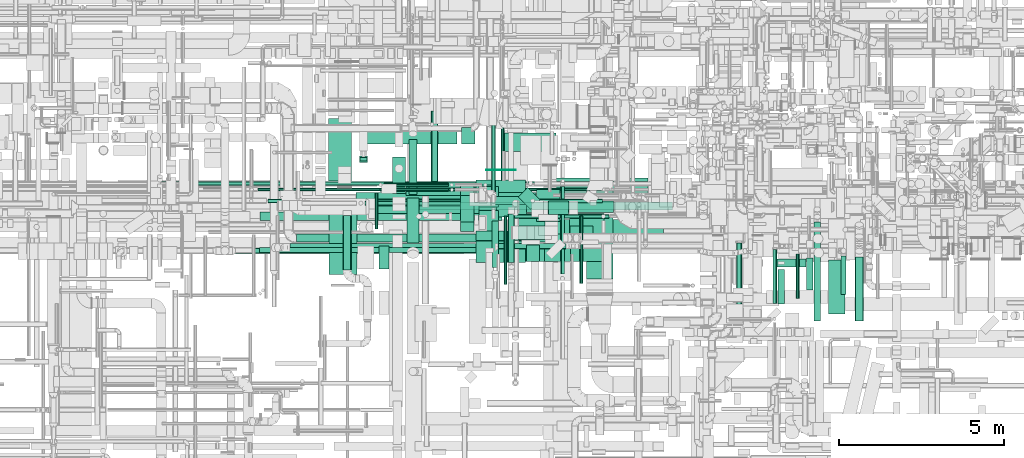
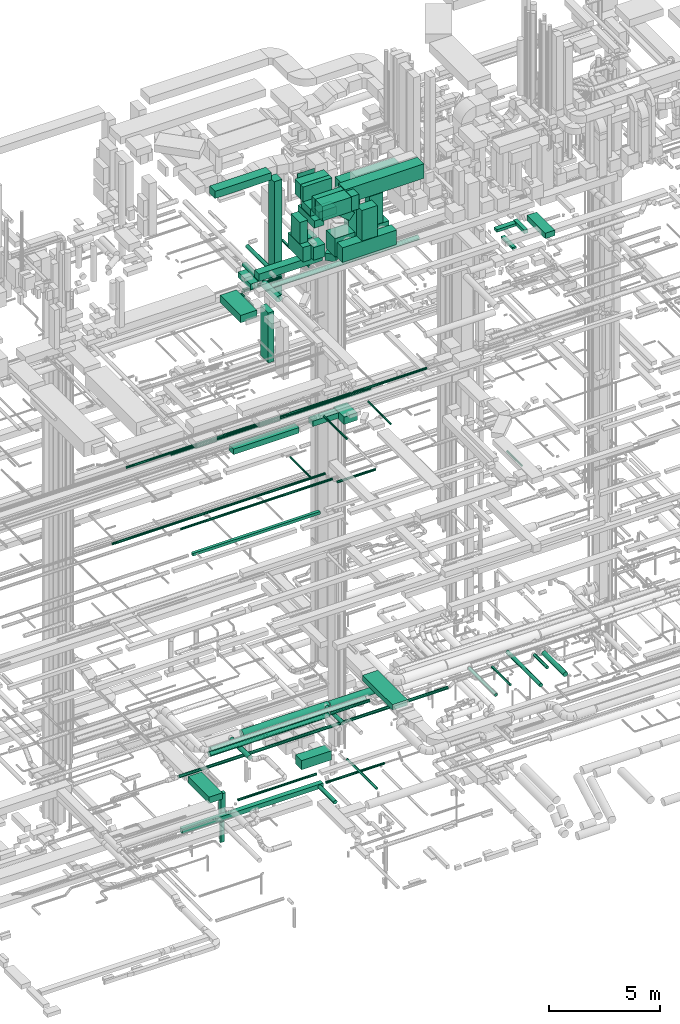
# One storey, part 40 of 337: 77 flow segments.
"""IFC2X3 building model written with IfcOpenShell, lengths in millimetres."""

from ifc_helpers import new_model, entity, si_unit, converted_unit, derived_unit, direction, frame, origin, origin_2d_with_axis, place, context, subcontext, project, spatial, rectangle, circle, extrude, type_object, element, save


model = new_model("IFC2X3")

# Units and contexts
model_context = context("Model", 3, precision=0.01, world=origin(), true_north=direction((6.12303176911189e-17, 1.0)))
body_context = subcontext(model_context, "Body", "Model", "MODEL_VIEW")
ifc_project = project(units=[si_unit("LENGTHUNIT", "METRE", prefix="MILLI"), si_unit("AREAUNIT", "SQUARE_METRE"), si_unit("VOLUMEUNIT", "CUBIC_METRE"), converted_unit("PLANEANGLEUNIT", "DEGREE", entity("IfcRatioMeasure", 0.0174532925199433), si_unit("PLANEANGLEUNIT", "RADIAN"), dimensions=[0, 0, 0, 0, 0, 0, 0]), si_unit("MASSUNIT", "GRAM", prefix="KILO"), derived_unit("MASSDENSITYUNIT", [(si_unit("MASSUNIT", "GRAM", prefix="KILO"), 1), (si_unit("LENGTHUNIT", "METRE"), -3)]), derived_unit("MOMENTOFINERTIAUNIT", [(si_unit("LENGTHUNIT", "METRE"), 4)]), si_unit("TIMEUNIT", "SECOND"), si_unit("FREQUENCYUNIT", "HERTZ"), si_unit("THERMODYNAMICTEMPERATUREUNIT", "DEGREE_CELSIUS"), derived_unit("THERMALTRANSMITTANCEUNIT", [(si_unit("MASSUNIT", "GRAM", prefix="KILO"), 1), (si_unit("THERMODYNAMICTEMPERATUREUNIT", "KELVIN"), -1), (si_unit("TIMEUNIT", "SECOND"), -3)]), derived_unit("VOLUMETRICFLOWRATEUNIT", [(si_unit("LENGTHUNIT", "METRE"), 3), (si_unit("TIMEUNIT", "SECOND"), -1)]), derived_unit("MASSFLOWRATEUNIT", [(si_unit("MASSUNIT", "GRAM", prefix="KILO"), 1), (si_unit("TIMEUNIT", "SECOND"), -1)]), derived_unit("ROTATIONALFREQUENCYUNIT", [(si_unit("TIMEUNIT", "SECOND"), -1)]), si_unit("ELECTRICCURRENTUNIT", "AMPERE"), si_unit("ELECTRICVOLTAGEUNIT", "VOLT"), si_unit("POWERUNIT", "WATT"), si_unit("FORCEUNIT", "NEWTON", prefix="KILO"), si_unit("ILLUMINANCEUNIT", "LUX"), si_unit("LUMINOUSFLUXUNIT", "LUMEN"), si_unit("LUMINOUSINTENSITYUNIT", "CANDELA"), derived_unit("USERDEFINED", [(si_unit("MASSUNIT", "GRAM", prefix="KILO"), -1), (si_unit("LENGTHUNIT", "METRE"), -2), (si_unit("TIMEUNIT", "SECOND"), 3), (si_unit("LUMINOUSFLUXUNIT", "LUMEN"), 1)]), derived_unit("LINEARVELOCITYUNIT", [(si_unit("LENGTHUNIT", "METRE"), 1), (si_unit("TIMEUNIT", "SECOND"), -1)]), si_unit("PRESSUREUNIT", "PASCAL"), derived_unit("USERDEFINED", [(si_unit("LENGTHUNIT", "METRE"), -2), (si_unit("MASSUNIT", "GRAM", prefix="KILO"), 1), (si_unit("TIMEUNIT", "SECOND"), -2)]), derived_unit("LINEARFORCEUNIT", [(si_unit("MASSUNIT", "GRAM", prefix="KILO"), 1), (si_unit("LENGTHUNIT", "METRE"), 1), (si_unit("TIMEUNIT", "SECOND"), -2), (si_unit("LENGTHUNIT", "METRE"), -1)]), derived_unit("PLANARFORCEUNIT", [(si_unit("MASSUNIT", "GRAM", prefix="KILO"), 1), (si_unit("LENGTHUNIT", "METRE"), 1), (si_unit("TIMEUNIT", "SECOND"), -2), (si_unit("LENGTHUNIT", "METRE"), -2)])], contexts=[model_context])

# Site, building, storey
site_placement = place(None, origin())
site = spatial("IfcSite", under=ifc_project, at=site_placement, CompositionType="ELEMENT")
building_placement = place(site_placement, origin())
building = spatial("IfcBuilding", under=site, at=building_placement, CompositionType="ELEMENT")
storey_placement = place(building_placement, origin())
storey = spatial("IfcBuildingStorey", under=building, at=storey_placement, CompositionType="ELEMENT", Elevation=0.0)

# Flow segments
duct_segment_type_1 = type_object("IfcDuctSegmentType", PredefinedType="NOTDEFINED")
flow_segment_1_placement = place(storey_placement, frame((37959.51, 10320.01, -800.0)))
element("IfcFlowSegment", 1, at=flow_segment_1_placement, inside=storey, type_object=duct_segment_type_1, context=body_context, shape_type="SweptSolid", body=[
    extrude(rectangle(XDim=1895.67384788931, YDim=700.000000000001, at=origin_2d_with_axis()), frame((350.0, 947.84, 0.0), z_axis=(0.0, 0.0, 1.0), x_axis=(0.0, 1.0, 0.0)), (0.0, 0.0, 1.0), 350.0),
])
flow_segment_2_placement = place(storey_placement, frame((43284.29, 11214.6, -1350.0)))
element("IfcFlowSegment", 2, at=flow_segment_2_placement, inside=storey, type_object=duct_segment_type_1, context=body_context, shape_type="SweptSolid", body=[
    extrude(rectangle(XDim=1570.65169441701, YDim=550.000000000001, at=origin_2d_with_axis()), frame((785.33, 275.0, 0.0), z_axis=(0.0, 0.0, 1.0), x_axis=(-1.0, 0.0, 0.0)), (0.0, 0.0, 1.0), 500.0),
])
flow_segment_3_placement = place(storey_placement, frame((38896.44, 10873.03, -2250.0)))
element("IfcFlowSegment", 3, at=flow_segment_3_placement, inside=storey, type_object=duct_segment_type_1, context=body_context, shape_type="SweptSolid", body=[
    extrude(rectangle(XDim=249.999999999999, YDim=200.0, at=origin_2d_with_axis()), frame((125.0, 100.0, 0.0)), (0.0, 0.0, 1.0), 1300.00004199995),
])
flow_segment_4_placement = place(storey_placement, frame((38921.44, 10923.03, -3660.0)))
element("IfcFlowSegment", 4, at=flow_segment_4_placement, inside=storey, type_object=duct_segment_type_1, context=body_context, shape_type="SweptSolid", body=[
    extrude(rectangle(XDim=99.9999999999989, YDim=199.999999999998, at=origin_2d_with_axis()), frame((100.0, 50.0, 0.0), z_axis=(0.0, 0.0, 1.0), x_axis=(0.0, -1.0, 0.0)), (0.0, 0.0, 1.0), 1109.99995800006),
])
flow_segment_5_placement = place(storey_placement, frame((35887.72, 9120.01, -1025.0)))
element("IfcFlowSegment", 5, at=flow_segment_5_placement, inside=storey, type_object=duct_segment_type_1, context=body_context, shape_type="SweptSolid", body=[
    extrude(rectangle(XDim=7324.49625800008, YDim=250.000000000001, at=origin_2d_with_axis()), frame((3662.25, 125.0, 0.0)), (0.0, 0.0, 1.0), 250.0),
])
flow_segment_6_placement = place(storey_placement, frame((42932.11, 9560.56, 18650.0)))
element("IfcFlowSegment", 6, at=flow_segment_6_placement, inside=storey, type_object=duct_segment_type_1, context=body_context, shape_type="SweptSolid", body=[
    extrude(rectangle(XDim=1318.1063930437, YDim=400.0, at=origin_2d_with_axis()), frame((659.05, 200.0, 0.0), z_axis=(0.0, 0.0, 1.0), x_axis=(-1.0, 0.0, 0.0)), (0.0, 0.0, 1.0), 300.000000000001),
])
flow_segment_7_placement = place(storey_placement, frame((44270.22, 9096.34, 18575.0)))
element("IfcFlowSegment", 7, at=flow_segment_7_placement, inside=storey, type_object=duct_segment_type_1, context=body_context, shape_type="SweptSolid", body=[
    extrude(rectangle(XDim=960.0, YDim=699.999999999997, at=origin_2d_with_axis()), frame((350.0, 480.0, 0.0), z_axis=(0.0, 0.0, 1.0), x_axis=(0.0, -1.0, 0.0)), (0.0, 0.0, 1.0), 400.0),
])
flow_segment_8_placement = place(storey_placement, frame((35870.56, 8144.63, 14850.0)))
element("IfcFlowSegment", 8, at=flow_segment_8_placement, inside=storey, type_object=duct_segment_type_1, context=body_context, shape_type="SweptSolid", body=[
    extrude(rectangle(XDim=6620.00000000006, YDim=150.000000000001, at=origin_2d_with_axis()), frame((3310.0, 75.0, 0.0), z_axis=(0.0, 0.0, 1.0), x_axis=(-1.0, 0.0, 0.0)), (0.0, 0.0, 1.0), 150.000000000001),
])
flow_segment_9_placement = place(storey_placement, frame((53115.82, 6282.55, 27400.0)))
element("IfcFlowSegment", 9, at=flow_segment_9_placement, inside=storey, type_object=duct_segment_type_1, context=body_context, shape_type="SweptSolid", body=[
    extrude(rectangle(XDim=1643.01593128804, YDim=499.999999999999, at=origin_2d_with_axis()), frame((250.0, 821.51, 0.0), z_axis=(0.0, 0.0, 1.0), x_axis=(0.0, -1.0, 0.0)), (0.0, 0.0, 1.0), 300.000000000001),
])
flow_segment_10_placement = place(storey_placement, frame((52445.02, 7019.99, 27450.0)))
element("IfcFlowSegment", 10, at=flow_segment_10_placement, inside=storey, type_object=duct_segment_type_1, context=body_context, shape_type="SweptSolid", body=[
    extrude(rectangle(XDim=960.80000000287, YDim=199.999999999998, at=origin_2d_with_axis()), frame((100.0, 480.4, 0.0), z_axis=(0.0, 0.0, 1.0), x_axis=(0.0, -1.0, 0.0)), (0.0, 0.0, 1.0), 199.999999999998),
])
flow_segment_11_placement = place(storey_placement, frame((51425.02, 7708.07, 27475.0)))
element("IfcFlowSegment", 11, at=flow_segment_11_placement, inside=storey, type_object=duct_segment_type_1, context=body_context, shape_type="SweptSolid", body=[
    extrude(rectangle(XDim=1000.00000000006, YDim=249.999999999999, at=origin_2d_with_axis()), frame((500.0, 125.0, 0.0)), (0.0, 0.0, 1.0), 150.000000000001),
])
flow_segment_12_placement = place(storey_placement, frame((51586.05, 6591.62, 27150.0)))
element("IfcFlowSegment", 12, at=flow_segment_12_placement, inside=storey, type_object=duct_segment_type_1, context=body_context, shape_type="SweptSolid", body=[
    extrude(rectangle(XDim=1041.44660940674, YDim=199.999999999998, at=origin_2d_with_axis()), frame((100.0, 520.72, 0.0), z_axis=(0.0, 0.0, 1.0), x_axis=(0.0, 1.0, 0.0)), (0.0, 0.0, 1.0), 100.000000000003),
])
flow_segment_13_placement = place(storey_placement, frame((44626.69, 9306.67, 27350.0)))
element("IfcFlowSegment", 13, at=flow_segment_13_placement, inside=storey, type_object=duct_segment_type_1, context=body_context, shape_type="SweptSolid", body=[
    extrude(rectangle(XDim=400.000000000001, YDim=600.000000000002, at=origin_2d_with_axis()), frame((300.0, 200.0, 0.0), z_axis=(0.0, 0.0, 1.0), x_axis=(0.0, -1.0, 0.0)), (0.0, 0.0, 1.0), 3330.0),
])
flow_segment_14_placement = place(storey_placement, frame((40313.85, 9882.41, 27350.0)))
element("IfcFlowSegment", 14, at=flow_segment_14_placement, inside=storey, type_object=duct_segment_type_1, context=body_context, shape_type="SweptSolid", body=[
    extrude(rectangle(XDim=3290.02525316941, YDim=400.0, at=origin_2d_with_axis()), frame((1645.01, 200.0, 0.0)), (0.0, 0.0, 1.0), 399.999999999996),
])
flow_segment_15_placement = place(storey_placement, frame((38798.74, 9560.56, 18550.0)))
element("IfcFlowSegment", 15, at=flow_segment_15_placement, inside=storey, type_object=duct_segment_type_1, context=body_context, shape_type="SweptSolid", body=[
    extrude(rectangle(XDim=3408.10639304378, YDim=400.0, at=origin_2d_with_axis()), frame((1704.05, 200.0, 0.0)), (0.0, 0.0, 1.0), 300.000000000001),
])
flow_segment_16_placement = place(storey_placement, frame((38920.03, 11440.3, 31450.0)))
element("IfcFlowSegment", 16, at=flow_segment_16_placement, inside=storey, type_object=duct_segment_type_1, context=body_context, shape_type="SweptSolid", body=[
    extrude(rectangle(XDim=2927.60197550554, YDim=500.000000000001, at=origin_2d_with_axis()), frame((1463.8, 250.0, 0.0)), (0.0, 0.0, 1.0), 399.999999999996),
])
flow_segment_17_placement = place(storey_placement, frame((42435.45, 7846.66, 31160.0)))
element("IfcFlowSegment", 17, at=flow_segment_17_placement, inside=storey, type_object=duct_segment_type_1, context=body_context, shape_type="SweptSolid", body=[
    extrude(rectangle(XDim=657.000000000002, YDim=1500.0, at=origin_2d_with_axis()), frame((750.0, 328.5, 0.0), z_axis=(0.0, 0.0, 1.0), x_axis=(0.0, -1.0, 0.0)), (0.0, 0.0, 1.0), 800.0),
])
flow_segment_18_placement = place(storey_placement, frame((37970.62, 7487.81, 27350.0)))
element("IfcFlowSegment", 18, at=flow_segment_18_placement, inside=storey, type_object=duct_segment_type_1, context=body_context, shape_type="SweptSolid", body=[
    extrude(rectangle(XDim=1852.15580735637, YDim=850.000000000002, at=origin_2d_with_axis()), frame((425.0, 926.08, 0.0), z_axis=(0.0, 0.0, 1.0), x_axis=(0.0, 1.0, 0.0)), (0.0, 0.0, 1.0), 399.999999999996),
])
flow_segment_19_placement = place(storey_placement, frame((39495.62, 7650.31, 24500.0)))
element("IfcFlowSegment", 19, at=flow_segment_19_placement, inside=storey, type_object=duct_segment_type_1, context=body_context, shape_type="SweptSolid", body=[
    extrude(rectangle(XDim=700.000000000001, YDim=300.000000000001, at=origin_2d_with_axis()), frame((150.0, 350.0, 0.0), z_axis=(0.0, 0.0, 1.0), x_axis=(0.0, 1.0, 0.0)), (0.0, 0.0, 1.0), 2750.0),
])
flow_segment_20_placement = place(storey_placement, frame((42735.45, 10646.66, 31460.0)))
element("IfcFlowSegment", 20, at=flow_segment_20_placement, inside=storey, type_object=duct_segment_type_1, context=body_context, shape_type="SweptSolid", body=[
    extrude(rectangle(XDim=5.17184841368411, YDim=900.000000000003, at=origin_2d_with_axis()), frame((450.0, 2.59, 0.0), z_axis=(0.0, 0.0, 1.0), x_axis=(0.0, 1.0, 0.0)), (0.0, 0.0, 1.0), 499.999999999999),
])
flow_segment_21_placement = place(storey_placement, frame((43955.45, 7874.6, 31151.2)))
element("IfcFlowSegment", 21, at=flow_segment_21_placement, inside=storey, type_object=duct_segment_type_1, context=body_context, shape_type="SweptSolid", body=[
    extrude(rectangle(XDim=393.267745000608, YDim=500.0, at=origin_2d_with_axis()), frame((196.63, 250.0, 0.0)), (0.0, 0.0, 1.0), 800.0),
])
flow_segment_22_placement = place(storey_placement, frame((42435.45, 9849.66, 31160.0)))
element("IfcFlowSegment", 22, at=flow_segment_22_placement, inside=storey, type_object=duct_segment_type_1, context=body_context, shape_type="SweptSolid", body=[
    extrude(rectangle(XDim=496.999999999887, YDim=1500.0, at=origin_2d_with_axis()), frame((750.0, 248.5, 0.0), z_axis=(0.0, 0.0, 1.0), x_axis=(0.0, -1.0, 0.0)), (0.0, 0.0, 1.0), 800.0),
])
flow_segment_23_placement = place(storey_placement, frame((42435.45, 9601.2, 31160.0)))
element("IfcFlowSegment", 23, at=flow_segment_23_placement, inside=storey, type_object=duct_segment_type_1, context=body_context, shape_type="SweptSolid", body=[
    extrude(rectangle(XDim=242.458659614557, YDim=1500.0, at=origin_2d_with_axis()), frame((750.0, 121.23, 0.0), z_axis=(0.0, 0.0, 1.0), x_axis=(0.0, -1.0, 0.0)), (0.0, 0.0, 1.0), 800.0),
])
flow_segment_24_placement = place(storey_placement, frame((42435.45, 8509.66, 31160.0)))
element("IfcFlowSegment", 24, at=flow_segment_24_placement, inside=storey, type_object=duct_segment_type_1, context=body_context, shape_type="SweptSolid", body=[
    extrude(rectangle(XDim=291.541340385442, YDim=1500.0, at=origin_2d_with_axis()), frame((750.0, 145.77, 0.0), z_axis=(0.0, 0.0, 1.0), x_axis=(0.0, 1.0, 0.0)), (0.0, 0.0, 1.0), 800.0),
])
flow_segment_25_placement = place(storey_placement, frame((44498.71, 7874.6, 29320.0)))
element("IfcFlowSegment", 25, at=flow_segment_25_placement, inside=storey, type_object=duct_segment_type_1, context=body_context, shape_type="SweptSolid", body=[
    extrude(rectangle(XDim=800.000000000009, YDim=500.0, at=origin_2d_with_axis()), frame((400.0, 250.0, 0.0)), (0.0, 0.0, 1.0), 1681.19764904033),
])
flow_segment_26_placement = place(storey_placement, frame((43488.79, 7874.6, 28500.0)))
element("IfcFlowSegment", 26, at=flow_segment_26_placement, inside=storey, type_object=duct_segment_type_1, context=body_context, shape_type="SweptSolid", body=[
    extrude(rectangle(XDim=2820.0, YDim=500.0, at=origin_2d_with_axis()), frame((1410.0, 250.0, 0.0)), (0.0, 0.0, 1.0), 800.0),
])
for number, where in (
    (27, (45268.79, 8549.6, 28400.0)),
    (28, (43482.17, 8549.6, 28400.0)),
):
    element("IfcFlowSegment", number, at=place(storey_placement, frame(where)), inside=storey, type_object=duct_segment_type_1, context=body_context, shape_type="SweptSolid", body=[
        extrude(rectangle(XDim=1040.0, YDim=780.0, at=origin_2d_with_axis()), frame((520.0, 390.0, 0.0), z_axis=(0.0, 0.0, 1.0), x_axis=(-1.0, 0.0, 0.0)), (0.0, 0.0, 1.0), 1000.0),
    ])
flow_segment_27_placement = place(storey_placement, frame((43697.38, 8549.6, 30135.0)))
element("IfcFlowSegment", 29, at=flow_segment_27_placement, inside=storey, type_object=duct_segment_type_1, context=body_context, shape_type="SweptSolid", body=[
    extrude(rectangle(XDim=442.273616793504, YDim=400.0, at=origin_2d_with_axis()), frame((139.96, 200.0, 614.25), z_axis=(0.774227896782653, 0.0, -0.632906915623071), x_axis=(0.632906915623071, 0.0, 0.774227896782653)), (0.0, 0.0, 1.0), 700.000000000017),
])
flow_segment_28_placement = place(storey_placement, frame((45277.02, 8549.6, 29420.0)))
element("IfcFlowSegment", 30, at=flow_segment_28_placement, inside=storey, type_object=duct_segment_type_1, context=body_context, shape_type="SweptSolid", body=[
    extrude(rectangle(XDim=699.999999999997, YDim=400.0, at=origin_2d_with_axis()), frame((350.0, 200.0, 0.0)), (0.0, 0.0, 1.0), 1659.99997499999),
])
flow_segment_29_placement = place(storey_placement, frame((44012.75, 8549.6, 31100.0)))
element("IfcFlowSegment", 31, at=flow_segment_29_placement, inside=storey, type_object=duct_segment_type_1, context=body_context, shape_type="SweptSolid", body=[
    extrude(rectangle(XDim=4105.22167691267, YDim=600.0, at=origin_2d_with_axis()), frame((2052.61, 300.0, 0.0)), (0.0, 0.0, 1.0), 800.0),
])
flow_segment_30_placement = place(storey_placement, frame((43035.03, 9223.67, 30200.0)))
element("IfcFlowSegment", 32, at=flow_segment_30_placement, inside=storey, type_object=duct_segment_type_1, context=body_context, shape_type="SweptSolid", body=[
    extrude(rectangle(XDim=920.00663499999, YDim=500.0, at=origin_2d_with_axis()), frame((460.0, 250.0, 0.0), z_axis=(0.0, 0.0, 1.0), x_axis=(-1.0, 0.0, 0.0)), (0.0, 0.0, 1.0), 399.999999999996),
])
flow_segment_31_placement = place(storey_placement, frame((42515.03, 8729.25, 30200.0)))
element("IfcFlowSegment", 33, at=flow_segment_31_placement, inside=storey, type_object=duct_segment_type_1, context=body_context, shape_type="SweptSolid", body=[
    extrude(rectangle(XDim=1460.0, YDim=499.999999999999, at=origin_2d_with_axis()), frame((250.0, 730.0, 0.0), z_axis=(0.0, 0.0, 1.0), x_axis=(0.0, -1.0, 0.0)), (0.0, 0.0, 1.0), 399.999999999996),
])
flow_segment_32_placement = place(storey_placement, frame((42519.03, 8793.67, 28400.0)))
element("IfcFlowSegment", 34, at=flow_segment_32_placement, inside=storey, type_object=duct_segment_type_1, context=body_context, shape_type="SweptSolid", body=[
    extrude(rectangle(XDim=630.0, YDim=589.999999999996, at=origin_2d_with_axis()), frame((295.0, 315.0, 0.0), z_axis=(0.0, 0.0, 1.0), x_axis=(0.0, -1.0, 0.0)), (0.0, 0.0, 1.0), 699.999999999997),
])
flow_segment_33_placement = place(storey_placement, frame((42517.57, 9523.67, 28400.0)))
element("IfcFlowSegment", 35, at=flow_segment_33_placement, inside=storey, type_object=duct_segment_type_1, context=body_context, shape_type="SweptSolid", body=[
    extrude(rectangle(XDim=630.0, YDim=589.999999999996, at=origin_2d_with_axis()), frame((295.0, 315.0, 0.0), z_axis=(0.0, 0.0, 1.0), x_axis=(0.0, 1.0, 0.0)), (0.0, 0.0, 1.0), 699.999999999997),
])
flow_segment_34_placement = place(storey_placement, frame((42515.03, 9073.67, 30650.0)))
element("IfcFlowSegment", 36, at=flow_segment_34_placement, inside=storey, type_object=duct_segment_type_1, context=body_context, shape_type="SweptSolid", body=[
    extrude(rectangle(XDim=537.83132499997, YDim=800.0, at=origin_2d_with_axis()), frame((268.92, 400.0, 0.0)), (0.0, 0.0, 1.0), 399.999999999996),
])
flow_segment_35_placement = place(storey_placement, frame((41965.03, 9073.67, 29320.0)))
element("IfcFlowSegment", 37, at=flow_segment_35_placement, inside=storey, type_object=duct_segment_type_1, context=body_context, shape_type="SweptSolid", body=[
    extrude(rectangle(XDim=799.999999999999, YDim=400.000000000004, at=origin_2d_with_axis()), frame((200.0, 400.0, 0.0), z_axis=(0.0, 0.0, 1.0), x_axis=(0.0, -1.0, 0.0)), (0.0, 0.0, 1.0), 1180.00002499995),
])
flow_segment_36_placement = place(storey_placement, frame((41965.03, 8785.16, 28500.0)))
element("IfcFlowSegment", 38, at=flow_segment_36_placement, inside=storey, type_object=duct_segment_type_1, context=body_context, shape_type="SweptSolid", body=[
    extrude(rectangle(XDim=1373.29352000001, YDim=400.000000000004, at=origin_2d_with_axis()), frame((200.0, 686.65, 0.0), z_axis=(0.0, 0.0, 1.0), x_axis=(0.0, -1.0, 0.0)), (0.0, 0.0, 1.0), 800.0),
])
flow_segment_37_placement = place(storey_placement, frame((44564.13, 9214.73, 30700.0)))
element("IfcFlowSegment", 39, at=flow_segment_37_placement, inside=storey, type_object=duct_segment_type_1, context=body_context, shape_type="SweptSolid", body=[
    extrude(rectangle(XDim=3071.75386999999, YDim=1200.0, at=origin_2d_with_axis()), frame((1535.88, 600.0, 0.0)), (0.0, 0.0, 1.0), 600.000000000002),
])
flow_segment_38_placement = place(storey_placement, frame((41997.64, 11440.3, 24950.0)))
element("IfcFlowSegment", 40, at=flow_segment_38_placement, inside=storey, type_object=duct_segment_type_1, context=body_context, shape_type="SweptSolid", body=[
    extrude(rectangle(XDim=499.999999999999, YDim=399.999999999996, at=origin_2d_with_axis()), frame((200.0, 250.0, 0.0), z_axis=(0.0, 0.0, 1.0), x_axis=(0.0, -1.0, 0.0)), (0.0, 0.0, 1.0), 6350.00000000007),
])
flow_segment_39_placement = place(storey_placement, frame((45775.84, 7345.85, 3400.0)))
element("IfcFlowSegment", 41, at=flow_segment_39_placement, inside=storey, type_object=duct_segment_type_1, context=body_context, shape_type="SweptSolid", body=[
    extrude(rectangle(XDim=2679.69805895098, YDim=800.0, at=origin_2d_with_axis()), frame((400.0, 1339.85, 0.0), z_axis=(0.0, 0.0, 1.0), x_axis=(0.0, -1.0, 0.0)), (0.0, 0.0, 1.0), 300.0),
])
flow_segment_40_placement = place(storey_placement, frame((43709.94, 9467.32, 27350.0)))
element("IfcFlowSegment", 42, at=flow_segment_40_placement, inside=storey, type_object=duct_segment_type_1, context=body_context, shape_type="SweptSolid", body=[
    extrude(rectangle(XDim=524.888527116787, YDim=399.999999999999, at=origin_2d_with_axis()), frame((327.0, 327.0, 0.0), z_axis=(0.0, 0.0, 1.0), x_axis=(0.707106781186518, -0.707106781186577, 0.0)), (0.0, 0.0, 1.0), 400.000000000004),
])
flow_segment_41_placement = place(storey_placement, frame((39895.11, 9933.64, 27020.0)))
element("IfcFlowSegment", 43, at=flow_segment_41_placement, inside=storey, type_object=duct_segment_type_1, context=body_context, shape_type="SweptSolid", body=[
    extrude(rectangle(XDim=1112.69724297037, YDim=399.999999999996, at=origin_2d_with_axis()), frame((200.0, 556.35, 0.0), z_axis=(0.0, 0.0, 1.0), x_axis=(0.0, -1.0, 0.0)), (0.0, 0.0, 1.0), 300.000000000001),
])
duct_segment_type_2 = type_object("IfcDuctSegmentType", PredefinedType="NOTDEFINED")
flow_segment_42_placement = place(storey_placement, frame((39064.81, 9579.05, -639.1)))
element("IfcFlowSegment", 44, at=flow_segment_42_placement, inside=storey, type_object=duct_segment_type_2, context=body_context, shape_type="SweptSolid", body=[
    extrude(circle(Radius=62.5, at=origin_2d_with_axis()), frame((0.0, 64.1, 64.1), z_axis=(1.0, 0.0, 0.0), x_axis=(0.0, -1.0, 0.0)), (0.0, 0.0, 1.0), 4090.87691199999),
])
flow_segment_43_placement = place(storey_placement, frame((44986.38, 7490.44, -804.1)))
element("IfcFlowSegment", 45, at=flow_segment_43_placement, inside=storey, type_object=duct_segment_type_2, context=body_context, shape_type="SweptSolid", body=[
    extrude(circle(Radius=62.5, at=origin_2d_with_axis()), frame((64.1, 0.0, 64.1), z_axis=(0.0, 1.0, 0.0), x_axis=(1.0, 0.0, 0.0)), (0.0, 0.0, 1.0), 2655.63463470343),
])
flow_segment_44_placement = place(storey_placement, frame((43412.22, 9180.91, -964.1)))
element("IfcFlowSegment", 46, at=flow_segment_44_placement, inside=storey, type_object=duct_segment_type_2, context=body_context, shape_type="SweptSolid", body=[
    extrude(circle(Radius=62.5, at=origin_2d_with_axis()), frame((0.0, 64.1, 64.1), z_axis=(1.0, 0.0, 0.0), x_axis=(0.0, 1.0, 0.0)), (0.0, 0.0, 1.0), 3048.29595392129),
])
flow_segment_45_placement = place(storey_placement, frame((39189.14, 9330.9, 2878.4)))
element("IfcFlowSegment", 47, at=flow_segment_45_placement, inside=storey, type_object=duct_segment_type_2, context=body_context, shape_type="SweptSolid", body=[
    extrude(circle(Radius=200.0, at=origin_2d_with_axis()), frame((0.0, 201.6, 201.6), z_axis=(1.0, 0.0, 0.0), x_axis=(0.0, 1.0, 0.0)), (0.0, 0.0, 1.0), 4507.41471823188),
])
flow_segment_46_placement = place(storey_placement, frame((36786.94, 8170.92, 3423.4)))
element("IfcFlowSegment", 48, at=flow_segment_46_placement, inside=storey, type_object=duct_segment_type_2, context=body_context, shape_type="SweptSolid", body=[
    extrude(circle(Radius=125.0, at=origin_2d_with_axis()), frame((0.0, 126.6, 126.6), z_axis=(1.0, 0.0, 0.0), x_axis=(0.0, 1.0, 0.0)), (0.0, 0.0, 1.0), 6223.1850733762),
])
flow_segment_47_placement = place(storey_placement, frame((51428.59, 6609.11, 3175.9)))
element("IfcFlowSegment", 49, at=flow_segment_47_placement, inside=storey, type_object=duct_segment_type_2, context=body_context, shape_type="SweptSolid", body=[
    extrude(circle(Radius=62.5, at=origin_2d_with_axis()), frame((64.1, 0.0, 64.1), z_axis=(0.0, 1.0, 0.0), x_axis=(-1.0, 0.0, 0.0)), (0.0, 0.0, 1.0), 1633.39999999999),
])
flow_segment_48_placement = place(storey_placement, frame((35143.9, 8118.43, 2868.4)))
element("IfcFlowSegment", 50, at=flow_segment_48_placement, inside=storey, type_object=duct_segment_type_2, context=body_context, shape_type="SweptSolid", body=[
    extrude(circle(Radius=80.0, at=origin_2d_with_axis()), frame((0.0, 81.6, 81.6), z_axis=(1.0, 0.0, 0.0), x_axis=(0.0, -1.0, 0.0)), (0.0, 0.0, 1.0), 14007.2424639311),
])
flow_segment_49_placement = place(storey_placement, frame((38397.55, 7615.04, 3053.4)))
element("IfcFlowSegment", 51, at=flow_segment_49_placement, inside=storey, type_object=duct_segment_type_2, context=body_context, shape_type="SweptSolid", body=[
    extrude(circle(Radius=125.0, at=origin_2d_with_axis()), frame((126.6, 0.0, 126.6), z_axis=(0.0, 1.0, 0.0), x_axis=(1.0, 0.0, 0.0)), (0.0, 0.0, 1.0), 1648.71124203767),
])
flow_segment_50_placement = place(storey_placement, frame((36994.56, 8460.07, 3423.4)))
element("IfcFlowSegment", 52, at=flow_segment_50_placement, inside=storey, type_object=duct_segment_type_2, context=body_context, shape_type="SweptSolid", body=[
    extrude(circle(Radius=125.0, at=origin_2d_with_axis()), frame((0.0, 126.6, 126.6), z_axis=(1.0, 0.0, 0.0), x_axis=(0.0, -1.0, 0.0)), (0.0, 0.0, 1.0), 8074.43965571322),
])
flow_segment_51_placement = place(storey_placement, frame((35827.51, 10005.52, 19198.4)))
element("IfcFlowSegment", 53, at=flow_segment_51_placement, inside=storey, type_object=duct_segment_type_2, context=body_context, shape_type="SweptSolid", body=[
    extrude(circle(Radius=50.0, at=origin_2d_with_axis()), frame((0.0, 51.6, 51.6), z_axis=(1.0, 0.0, 0.0), x_axis=(0.0, 1.0, 0.0)), (0.0, 0.0, 1.0), 10405.0461405627),
])
flow_segment_52_placement = place(storey_placement, frame((45567.65, 7211.98, 19223.4)))
element("IfcFlowSegment", 54, at=flow_segment_52_placement, inside=storey, type_object=duct_segment_type_2, context=body_context, shape_type="SweptSolid", body=[
    extrude(circle(Radius=50.0, at=origin_2d_with_axis()), frame((51.6, 0.0, 51.6), z_axis=(0.0, 1.0, 0.0), x_axis=(-1.0, 0.0, 0.0)), (0.0, 0.0, 1.0), 2038.14341585328),
])
flow_segment_53_placement = place(storey_placement, frame((43269.57, 7185.33, 19223.4)))
element("IfcFlowSegment", 55, at=flow_segment_53_placement, inside=storey, type_object=duct_segment_type_2, context=body_context, shape_type="SweptSolid", body=[
    extrude(circle(Radius=50.0, at=origin_2d_with_axis()), frame((51.6, 0.0, 51.6), z_axis=(0.0, 1.0, 0.0), x_axis=(-1.0, 0.0, 0.0)), (0.0, 0.0, 1.0), 2064.78905220942),
])
flow_segment_54_placement = place(storey_placement, frame((36122.22, 9651.59, 15235.9)))
element("IfcFlowSegment", 56, at=flow_segment_54_placement, inside=storey, type_object=duct_segment_type_2, context=body_context, shape_type="SweptSolid", body=[
    extrude(circle(Radius=62.5, at=origin_2d_with_axis()), frame((0.0, 64.1, 64.1), z_axis=(1.0, 0.0, 0.0), x_axis=(0.0, -1.0, 0.0)), (0.0, 0.0, 1.0), 7900.00000000001),
])
flow_segment_55_placement = place(storey_placement, frame((44272.22, 9651.59, 14975.9)))
element("IfcFlowSegment", 57, at=flow_segment_55_placement, inside=storey, type_object=duct_segment_type_2, context=body_context, shape_type="SweptSolid", body=[
    extrude(circle(Radius=62.5, at=origin_2d_with_axis()), frame((0.0, 64.1, 64.1), z_axis=(1.0, 0.0, 0.0), x_axis=(0.0, -1.0, 0.0)), (0.0, 0.0, 1.0), 1990.0),
])
flow_segment_56_placement = place(storey_placement, frame((52128.38, 6759.63, 14898.4)))
element("IfcFlowSegment", 58, at=flow_segment_56_placement, inside=storey, type_object=duct_segment_type_2, context=body_context, shape_type="SweptSolid", body=[
    extrude(circle(Radius=50.0, at=origin_2d_with_axis()), frame((51.6, 0.0, 51.6), z_axis=(0.0, 1.0, 0.0), x_axis=(-1.0, 0.0, 0.0)), (0.0, 0.0, 1.0), 1340.00000000007),
])
flow_segment_57_placement = place(storey_placement, frame((43188.96, 10328.79, 15248.4)))
element("IfcFlowSegment", 59, at=flow_segment_57_placement, inside=storey, type_object=duct_segment_type_2, context=body_context, shape_type="SweptSolid", body=[
    extrude(circle(Radius=50.0, at=origin_2d_with_axis()), frame((51.6, 0.0, 51.6), z_axis=(0.0, 1.0, 0.0), x_axis=(1.0, 0.0, 0.0)), (0.0, 0.0, 1.0), 1811.5497082587),
])
flow_segment_58_placement = place(storey_placement, frame((32870.03, 10182.2, 15235.9)))
element("IfcFlowSegment", 60, at=flow_segment_58_placement, inside=storey, type_object=duct_segment_type_2, context=body_context, shape_type="SweptSolid", body=[
    extrude(circle(Radius=62.5, at=origin_2d_with_axis()), frame((0.0, 64.1, 64.1), z_axis=(1.0, 0.0, 0.0), x_axis=(0.0, -1.0, 0.0)), (0.0, 0.0, 1.0), 11087.0),
])
flow_segment_59_placement = place(storey_placement, frame((33599.89, 10173.3, 19185.9)))
element("IfcFlowSegment", 61, at=flow_segment_59_placement, inside=storey, type_object=duct_segment_type_2, context=body_context, shape_type="SweptSolid", body=[
    extrude(circle(Radius=62.5, at=origin_2d_with_axis()), frame((0.0, 64.1, 64.1), z_axis=(1.0, 0.0, 0.0), x_axis=(0.0, 1.0, 0.0)), (0.0, 0.0, 1.0), 15625.0),
])
flow_segment_60_placement = place(storey_placement, frame((40341.53, 8438.86, 27020.9)))
element("IfcFlowSegment", 62, at=flow_segment_60_placement, inside=storey, type_object=duct_segment_type_2, context=body_context, shape_type="SweptSolid", body=[
    extrude(circle(Radius=177.5, at=origin_2d_with_axis()), frame((179.1, 0.0, 179.1), z_axis=(0.0, 1.0, 0.0), x_axis=(-1.0, 0.0, 0.0)), (0.0, 0.0, 1.0), 1368.8445985982),
])
flow_segment_61_placement = place(storey_placement, frame((39365.48, 8864.63, 26898.4)))
element("IfcFlowSegment", 63, at=flow_segment_61_placement, inside=storey, type_object=duct_segment_type_2, context=body_context, shape_type="SweptSolid", body=[
    extrude(circle(Radius=50.0, at=origin_2d_with_axis()), frame((51.6, 0.0, 51.6), z_axis=(0.0, 1.0, 0.0), x_axis=(1.0, 0.0, 0.0)), (0.0, 0.0, 1.0), 1085.29999999997),
])
flow_segment_62_placement = place(storey_placement, frame((39636.81, 10148.35, 26898.4)))
element("IfcFlowSegment", 64, at=flow_segment_62_placement, inside=storey, type_object=duct_segment_type_2, context=body_context, shape_type="SweptSolid", body=[
    extrude(circle(Radius=50.0, at=origin_2d_with_axis()), frame((0.0, 51.6, 51.6), z_axis=(1.0, 0.0, 0.0), x_axis=(0.0, 1.0, 0.0)), (0.0, 0.0, 1.0), 1956.4213562378),
])
flow_segment_63_placement = place(storey_placement, frame((43741.56, 9353.4, 2900.9)))
element("IfcFlowSegment", 65, at=flow_segment_63_placement, inside=storey, type_object=duct_segment_type_2, context=body_context, shape_type="SweptSolid", body=[
    extrude(circle(Radius=177.5, at=origin_2d_with_axis()), frame((0.0, 179.1, 179.1), z_axis=(1.0, 0.0, 0.0), x_axis=(0.0, 1.0, 0.0)), (0.0, 0.0, 1.0), 2860.0),
])
flow_segment_64_placement = place(storey_placement, frame((43401.76, 7850.64, 3078.4)))
element("IfcFlowSegment", 66, at=flow_segment_64_placement, inside=storey, type_object=duct_segment_type_2, context=body_context, shape_type="SweptSolid", body=[
    extrude(circle(Radius=100.0, at=origin_2d_with_axis()), frame((101.6, 0.0, 101.6), z_axis=(0.0, 1.0, 0.0), x_axis=(1.0, 0.0, 0.0)), (0.0, 0.0, 1.0), 1461.86341432682),
])
flow_segment_65_placement = place(storey_placement, frame((50328.25, 6031.67, 3343.4)))
element("IfcFlowSegment", 67, at=flow_segment_65_placement, inside=storey, type_object=duct_segment_type_2, context=body_context, shape_type="SweptSolid", body=[
    extrude(circle(Radius=80.0, at=origin_2d_with_axis()), frame((81.6, 0.0, 81.6), z_axis=(0.0, 1.0, 0.0), x_axis=(-1.0, 0.0, 0.0)), (0.0, 0.0, 1.0), 2410.00000000047),
])
flow_segment_66_placement = place(storey_placement, frame((53920.34, 6073.94, 3123.4)))
element("IfcFlowSegment", 68, at=flow_segment_66_placement, inside=storey, type_object=duct_segment_type_2, context=body_context, shape_type="SweptSolid", body=[
    extrude(circle(Radius=125.0, at=origin_2d_with_axis()), frame((126.6, 0.0, 126.6), z_axis=(0.0, 1.0, 0.0), x_axis=(1.0, 0.0, 0.0)), (0.0, 0.0, 1.0), 1941.44660940672),
])
flow_segment_67_placement = place(storey_placement, frame((41071.5, 10302.41, 27348.4)))
element("IfcFlowSegment", 69, at=flow_segment_67_placement, inside=storey, type_object=duct_segment_type_2, context=body_context, shape_type="SweptSolid", body=[
    extrude(circle(Radius=100.0, at=origin_2d_with_axis()), frame((101.6, 0.0, 101.6), z_axis=(0.0, 1.0, 0.0), x_axis=(-1.0, 0.0, 0.0)), (0.0, 0.0, 1.0), 2129.10479746454),
])
flow_segment_68_placement = place(storey_placement, frame((40394.03, 9912.7, 27073.4)))
element("IfcFlowSegment", 70, at=flow_segment_68_placement, inside=storey, type_object=duct_segment_type_2, context=body_context, shape_type="SweptSolid", body=[
    extrude(circle(Radius=125.0, at=origin_2d_with_axis()), frame((126.6, 0.0, 126.6), z_axis=(0.0, 1.0, 0.0), x_axis=(1.0, 0.0, 0.0)), (0.0, 0.0, 1.0), 1658.9367358048),
])
flow_segment_69_placement = place(storey_placement, frame((42892.15, 9951.15, 27135.9)))
element("IfcFlowSegment", 71, at=flow_segment_69_placement, inside=storey, type_object=duct_segment_type_2, context=body_context, shape_type="SweptSolid", body=[
    extrude(circle(Radius=62.5, at=origin_2d_with_axis()), frame((64.1, 0.0, 64.1), z_axis=(0.0, 1.0, 0.0), x_axis=(-1.0, 0.0, 0.0)), (0.0, 0.0, 1.0), 2415.18461638555),
])
flow_segment_70_placement = place(storey_placement, frame((39517.07, 9998.34, 26898.4)))
element("IfcFlowSegment", 72, at=flow_segment_70_placement, inside=storey, type_object=duct_segment_type_2, context=body_context, shape_type="SweptSolid", body=[
    extrude(circle(Radius=50.0, at=origin_2d_with_axis()), frame((0.0, 51.6, 51.6), z_axis=(1.0, 0.0, 0.0), x_axis=(0.0, -1.0, 0.0)), (0.0, 0.0, 1.0), 2082.19838053792),
])
flow_segment_71_placement = place(storey_placement, frame((40712.33, 9429.63, 27028.4)))
element("IfcFlowSegment", 73, at=flow_segment_71_placement, inside=storey, type_object=duct_segment_type_2, context=body_context, shape_type="SweptSolid", body=[
    extrude(circle(Radius=125.0, at=origin_2d_with_axis()), frame((0.0, 126.6, 126.6), z_axis=(1.0, 0.0, 1.54467776198306e-06), x_axis=(0.0, -1.0, 0.0)), (0.0, 0.0, 1.0), 7680.00316098295),
])
flow_segment_72_placement = place(storey_placement, frame((43100.12, 8260.92, 3468.4)))
element("IfcFlowSegment", 74, at=flow_segment_72_placement, inside=storey, type_object=duct_segment_type_2, context=body_context, shape_type="SweptSolid", body=[
    extrude(circle(Radius=80.0, at=origin_2d_with_axis()), frame((0.0, 81.6, 81.6), z_axis=(1.0, 0.0, 0.0), x_axis=(0.0, 1.0, 0.0)), (0.0, 0.0, 1.0), 2056.9458300205),
])
flow_segment_73_placement = place(storey_placement, frame((53487.31, 6880.92, 3218.4)))
element("IfcFlowSegment", 75, at=flow_segment_73_placement, inside=storey, type_object=duct_segment_type_2, context=body_context, shape_type="SweptSolid", body=[
    extrude(circle(Radius=80.0, at=origin_2d_with_axis()), frame((81.6, 0.0, 81.6), z_axis=(0.0, 1.0, 0.0), x_axis=(-1.0, 0.0, 0.0)), (0.0, 0.0, 1.0), 1159.10000000005),
])
flow_segment_74_placement = place(storey_placement, frame((52670.27, 6073.94, 2998.4)))
element("IfcFlowSegment", 76, at=flow_segment_74_placement, inside=storey, type_object=duct_segment_type_2, context=body_context, shape_type="SweptSolid", body=[
    extrude(circle(Radius=100.0, at=origin_2d_with_axis()), frame((101.6, 0.0, 101.6), z_axis=(0.0, 1.0, 0.0), x_axis=(-1.0, 0.0, 0.0)), (0.0, 0.0, 1.0), 3006.57118741769),
])
flow_segment_75_placement = place(storey_placement, frame((42911.05, 7688.57, -1001.6)))
element("IfcFlowSegment", 77, at=flow_segment_75_placement, inside=storey, type_object=duct_segment_type_2, context=body_context, shape_type="SweptSolid", body=[
    extrude(circle(Radius=100.0, at=origin_2d_with_axis()), frame((101.6, 0.0, 101.6), z_axis=(0.0, 1.0, 0.0), x_axis=(-1.0, 0.0, 0.0)), (0.0, 0.0, 1.0), 1411.43726658223),
])

save(model, "model.ifc")
